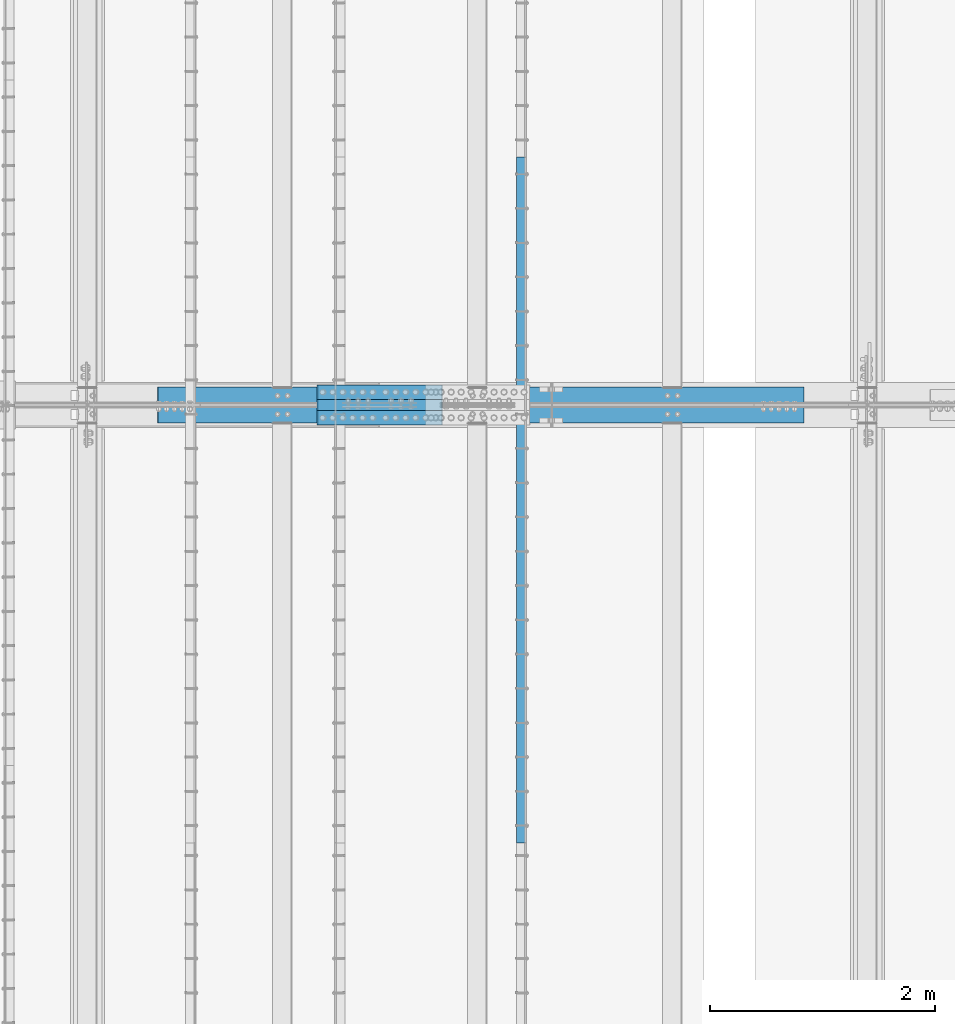
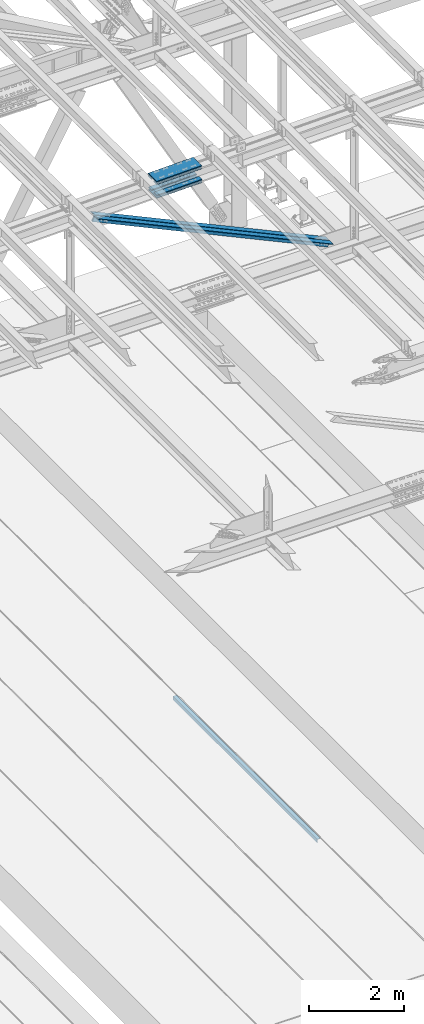
# One storey, part 1895 of 3843: 7 beams, 2 members, 4 elements without a shape of their own.
"""IFC2X3 building model written with IfcOpenShell, lengths in millimetres."""

from ifc_helpers import new_model, si_unit, frame, origin_with_axes, place, context, subcontext, project, spatial, faceted_brep, material, type_object, element, aggregate, save


model = new_model("IFC2X3")

# Units and contexts
model_context = context("Model", 3, precision=1e-05, world=origin_with_axes())
body_context = subcontext(model_context, "Body", "Model", "MODEL_VIEW")
ifc_project = project(units=[si_unit("LENGTHUNIT", "METRE", prefix="MILLI"), si_unit("AREAUNIT", "SQUARE_METRE"), si_unit("VOLUMEUNIT", "CUBIC_METRE"), si_unit("MASSUNIT", "GRAM", prefix="KILO"), si_unit("TIMEUNIT", "SECOND"), si_unit("PLANEANGLEUNIT", "RADIAN"), si_unit("SOLIDANGLEUNIT", "STERADIAN"), si_unit("THERMODYNAMICTEMPERATUREUNIT", "DEGREE_CELSIUS"), si_unit("LUMINOUSINTENSITYUNIT", "LUMEN")], contexts=[model_context])

# Site, building, storey
site_placement = place(None, origin_with_axes())
site = spatial("IfcSite", under=ifc_project, at=site_placement, CompositionType="ELEMENT")
building_placement = place(site_placement, origin_with_axes())
building = spatial("IfcBuilding", under=site, at=building_placement, Name="Undefined", CompositionType="ELEMENT")
storey_placement = place(building_placement, origin_with_axes())
storey = spatial("IfcBuildingStorey", under=building, at=storey_placement, Name="Undefined", CompositionType="ELEMENT", Elevation=0.0)

# Assembly, beam
assembly_1_placement = place(storey_placement, origin_with_axes())
assembly_1 = element("IfcElementAssembly", 1, at=assembly_1_placement, inside=storey, Name="EMBED_ANGLE", AssemblyPlace="NOTDEFINED", PredefinedType="RIGID_FRAME")
ifc_material_1 = material(Name="STEEL/A36")
beam_type_1 = type_object("IfcBeamType", Name="L3-1/2X3-1/2X5/16", PredefinedType="NOTDEFINED")
beam_1_placement = place(assembly_1_placement, frame((52851.812, 77831.822703125, 30410.15), z_axis=(0.0, 0.0, -1.0), x_axis=(0.0, -1.0, 0.0)))
beam_1 = element("IfcBeam", 2, at=beam_1_placement, type_object=beam_type_1, material=ifc_material_1, Name="EMBED_ANGLE", ObjectType="L3-1/2X3-1/2X5/16", context=body_context, shape_type="Brep", body=[
    faceted_brep([(-3.63797880709171e-12, 44.4499999999971, -44.4500000000007), (-3.63797880709171e-12, 44.4499999999971, 44.4500000000007), (6096.0, 44.4499999999971, 44.4500000000007), (6096.0, 44.4499999999971, -44.4500000000007), (-3.63797880709171e-12, 36.5124999999971, 44.4500000000007), (6096.0, 36.5124999999971, 44.4500000000007), (-3.63797880709171e-12, 36.5124999999971, -36.5125000000007), (6096.0, 36.5124999999971, -36.5125000000007), (3.63797880709171e-12, -44.4499999999971, -36.5125000000007), (6096.0, -44.4499999999971, -36.5125000000007), (3.63797880709171e-12, -44.4499999999971, -44.4500000000007), (6096.0, -44.4499999999971, -44.4500000000007)], [[[0, 1, 2, 3]], [[1, 4, 5, 2]], [[4, 6, 7, 5]], [[6, 8, 9, 7]], [[8, 10, 11, 9]], [[10, 0, 3, 11]], [[5, 7, 9, 11, 3, 2]], [[10, 8, 6, 4, 1, 0]]]),
])
aggregate(assembly_1, [beam_1])

# Assembly, beams
assembly_2_placement = place(storey_placement, origin_with_axes())
assembly_2 = element("IfcElementAssembly", 3, at=assembly_2_placement, inside=storey, Name="BEAM", AssemblyPlace="NOTDEFINED", PredefinedType="RIGID_FRAME")
ifc_material_2 = material(Name="STEEL/A572-50")
beam_type_2 = type_object("IfcBeamType", PredefinedType="NOTDEFINED")
beam_2_placement = place(assembly_2_placement, frame((51036.2821561572, 75742.8, 45733.0018265796), z_axis=(0.0, -1.0, 0.0), x_axis=(0.999715775508226, 0.0, 0.0238404739882768)))
beam_2 = element("IfcBeam", 4, at=beam_2_placement, type_object=beam_type_2, material=ifc_material_2, Name="PLATE", context=body_context, shape_type="Brep", body=[
    faceted_brep([(-4.36557456851006e-11, 12.7000000000116, -63.5), (-4.36557456851006e-11, 12.7000000000116, 63.5), (1104.90000001677, 12.7000000017251, 63.5), (1104.90000001677, 12.7000000017251, -63.5), (1.45519152283669e-11, -12.700000000008, 63.5), (1104.90000001682, -12.6999999982909, 63.5), (1.45519152283669e-11, -12.700000000008, -63.5), (1104.90000001682, -12.6999999982909, -63.5)], [[[0, 1, 2, 3]], [[1, 4, 5, 2]], [[4, 6, 7, 5]], [[6, 0, 3, 7]], [[5, 7, 3, 2]], [[6, 4, 1, 0]]]),
])
beam_3_placement = place(assembly_2_placement, frame((51043.3215286276, 75742.8, 45437.8151863273), z_axis=(0.0, -1.0, 0.0), x_axis=(0.999715775508226, 0.0, 0.0238404739882768)))
beam_3 = element("IfcBeam", 5, at=beam_3_placement, type_object=beam_type_2, material=ifc_material_2, Name="PLATE", context=body_context, shape_type="Brep", body=[
    faceted_brep([(-4.36557456851006e-11, 12.7000000000116, -63.5), (-4.36557456851006e-11, 12.7000000000116, 63.5), (1104.90000001677, 12.7000000017251, 63.5), (1104.90000001677, 12.7000000017251, -63.5), (1.45519152283669e-11, -12.700000000008, 63.5), (1104.90000001682, -12.6999999982909, 63.5), (1.45519152283669e-11, -12.700000000008, -63.5), (1104.90000001682, -12.6999999982909, -63.5)], [[[0, 1, 2, 3]], [[1, 4, 5, 2]], [[4, 6, 7, 5]], [[6, 0, 3, 7]], [[5, 7, 3, 2]], [[6, 4, 1, 0]]]),
])
beam_4_placement = place(assembly_2_placement, frame((51036.2821561572, 75514.2, 45733.0018265796), z_axis=(0.0, -1.0, 0.0), x_axis=(0.999715775508226, 0.0, 0.0238404739882768)))
beam_4 = element("IfcBeam", 6, at=beam_4_placement, type_object=beam_type_2, material=ifc_material_2, Name="PLATE", context=body_context, shape_type="Brep", body=[
    faceted_brep([(-4.36557456851006e-11, 12.7000000000116, -63.5), (-4.36557456851006e-11, 12.7000000000116, 63.5), (1104.90000001677, 12.7000000017251, 63.5), (1104.90000001677, 12.7000000017251, -63.5), (1.45519152283669e-11, -12.700000000008, 63.5), (1104.90000001682, -12.6999999982909, 63.5), (1.45519152283669e-11, -12.700000000008, -63.5), (1104.90000001682, -12.6999999982909, -63.5)], [[[0, 1, 2, 3]], [[1, 4, 5, 2]], [[4, 6, 7, 5]], [[6, 0, 3, 7]], [[5, 7, 3, 2]], [[6, 4, 1, 0]]]),
])
beam_5_placement = place(assembly_2_placement, frame((51043.3215286276, 75514.2, 45437.8151863273), z_axis=(0.0, -1.0, 0.0), x_axis=(0.999715775508226, 0.0, 0.0238404739882768)))
beam_5 = element("IfcBeam", 7, at=beam_5_placement, type_object=beam_type_2, material=ifc_material_2, Name="PLATE", context=body_context, shape_type="Brep", body=[
    faceted_brep([(-4.36557456851006e-11, 12.7000000000116, -63.5), (-4.36557456851006e-11, 12.7000000000116, 63.5), (1104.90000001677, 12.7000000017251, 63.5), (1104.90000001677, 12.7000000017251, -63.5), (1.45519152283669e-11, -12.700000000008, 63.5), (1104.90000001682, -12.6999999982909, 63.5), (1.45519152283669e-11, -12.700000000008, -63.5), (1104.90000001682, -12.6999999982909, -63.5)], [[[0, 1, 2, 3]], [[1, 4, 5, 2]], [[4, 6, 7, 5]], [[6, 0, 3, 7]], [[5, 7, 3, 2]], [[6, 4, 1, 0]]]),
])
beam_type_3 = type_object("IfcBeamType", PredefinedType="NOTDEFINED")
beam_6_placement = place(assembly_2_placement, frame((52139.3904556641, 75628.5, 45821.3068921507), z_axis=(0.0, -1.0, 0.0), x_axis=(-0.999715775508227, 0.0, -0.0238404739882678)))
beam_6 = element("IfcBeam", 8, at=beam_6_placement, type_object=beam_type_3, material=ifc_material_2, Name="PLATE", context=body_context, shape_type="Brep", body=[
    faceted_brep([(-1.45519152283669e-11, 12.7000000000025, -177.800000000003), (-1.45519152283669e-11, 12.7000000000025, 177.800000000003), (1104.90000001682, 12.7000000017051, 177.800000000003), (1104.90000001682, 12.7000000017051, -177.800000000003), (4.36557456851006e-11, -12.7000000000171, 177.800000000003), (1104.90000001686, -12.6999999983072, 177.800000000003), (4.36557456851006e-11, -12.7000000000171, -177.800000000003), (1104.90000001686, -12.6999999983072, -177.800000000003)], [[[0, 1, 2, 3]], [[1, 4, 5, 2]], [[4, 6, 7, 5]], [[6, 0, 3, 7]], [[5, 7, 3, 2]], [[6, 4, 1, 0]]]),
])
beam_7_placement = place(assembly_2_placement, frame((52149.3856930014, 75628.5, 45402.2616085425), z_axis=(0.0, -1.0, 0.0), x_axis=(-0.999715775508227, 0.0, -0.0238404739882678)))
beam_7 = element("IfcBeam", 9, at=beam_7_placement, type_object=beam_type_3, material=ifc_material_2, Name="PLATE", context=body_context, shape_type="Brep", body=[
    faceted_brep([(-1.45519152283669e-11, 12.7000000000025, -177.800000000003), (-1.45519152283669e-11, 12.7000000000025, 177.800000000003), (1104.90000001682, 12.7000000017051, 177.800000000003), (1104.90000001682, 12.7000000017051, -177.800000000003), (4.36557456851006e-11, -12.7000000000171, 177.800000000003), (1104.90000001686, -12.6999999983072, 177.800000000003), (4.36557456851006e-11, -12.7000000000171, -177.800000000003), (1104.90000001686, -12.6999999983072, -177.800000000003)], [[[0, 1, 2, 3]], [[1, 4, 5, 2]], [[4, 6, 7, 5]], [[6, 0, 3, 7]], [[5, 7, 3, 2]], [[6, 4, 1, 0]]]),
])
aggregate(assembly_2, [beam_2, beam_3, beam_4, beam_5, beam_6, beam_7])

# Assembly, member
assembly_3_placement = place(storey_placement, origin_with_axes())
assembly_3 = element("IfcElementAssembly", 10, at=assembly_3_placement, inside=storey, Name="ANGLE", AssemblyPlace="NOTDEFINED", PredefinedType="RIGID_FRAME")
member_type = type_object("IfcMemberType", Name="L6X6X1/2", PredefinedType="NOTDEFINED")
member_1_placement = place(assembly_3_placement, frame((48996.6, 75714.225, 45536.2056553683), z_axis=(-0.421184550907302, 0.0, -0.906974957800388), x_axis=(0.906974957800388, 0.0, -0.421184550907301)))
member_1 = element("IfcMember", 11, at=member_1_placement, type_object=member_type, material=ifc_material_2, Name="ANGLE", ObjectType="L6X6X1/2", context=body_context, shape_type="Brep", body=[
    faceted_brep([(653.471706149714, 76.1999999999971, -76.2000000001208), (653.471706149714, 76.1999999999971, 76.1999999993495), (6986.37183533818, 76.1999999999971, 76.1999999955951), (6986.37183533818, 76.1999999999971, -76.2000000038897), (653.471706149714, 63.5, 76.1999999993495), (6986.37183533818, 63.5, 76.1999999955951), (653.471706149718, 63.5, -63.5000000001673), (6986.37183533817, 63.5, -63.500000003929), (653.471706149718, -76.1999999999971, -63.5000000001673), (6986.37183533817, -76.1999999999971, -63.500000003929), (653.471706149714, -76.1999999999971, -76.2000000001208), (6986.37183533818, -76.1999999999971, -76.2000000038897)], [[[0, 1, 2, 3]], [[1, 4, 5, 2]], [[4, 6, 7, 5]], [[6, 8, 9, 7]], [[8, 10, 11, 9]], [[10, 0, 3, 11]], [[5, 7, 9, 11, 3, 2]], [[10, 8, 6, 4, 1, 0]]]),
])
aggregate(assembly_3, [member_1])

assembly_4_placement = place(storey_placement, origin_with_axes())
assembly_4 = element("IfcElementAssembly", 12, at=assembly_4_placement, inside=storey, Name="ANGLE", AssemblyPlace="NOTDEFINED", PredefinedType="RIGID_FRAME")
member_2_placement = place(assembly_4_placement, frame((55930.7999981822, 75542.775, 42316.0749509872), z_axis=(-0.421184550907302, 0.0, -0.906974957800388), x_axis=(-0.906974957800387, 0.0, 0.421184550907303)))
member_2 = element("IfcMember", 13, at=member_2_placement, type_object=member_type, material=ifc_material_2, Name="ANGLE", ObjectType="L6X6X1/2", context=body_context, shape_type="Brep", body=[
    faceted_brep([(659.043219927345, 76.1999999999971, -76.1999999993495), (659.043219927353, 76.1999999999971, 76.2000000001281), (6991.9433491158, 76.1999999999971, 76.2000000038897), (6991.9433491158, 76.1999999999971, -76.1999999955951), (659.043219927353, 63.5, 76.2000000001281), (6991.9433491158, 63.5, 76.2000000038897), (659.043219927349, 63.5, -63.4999999993961), (6991.94334911581, 63.5, -63.4999999956417), (659.043219927349, -76.1999999999971, -63.4999999993961), (6991.94334911581, -76.1999999999971, -63.4999999956417), (659.043219927345, -76.1999999999971, -76.1999999993495), (6991.9433491158, -76.1999999999971, -76.1999999955951)], [[[0, 1, 2, 3]], [[1, 4, 5, 2]], [[4, 6, 7, 5]], [[6, 8, 9, 7]], [[8, 10, 11, 9]], [[10, 0, 3, 11]], [[5, 7, 9, 11, 3, 2]], [[10, 8, 6, 4, 1, 0]]]),
])
aggregate(assembly_4, [member_2])

save(model, "model.ifc")
